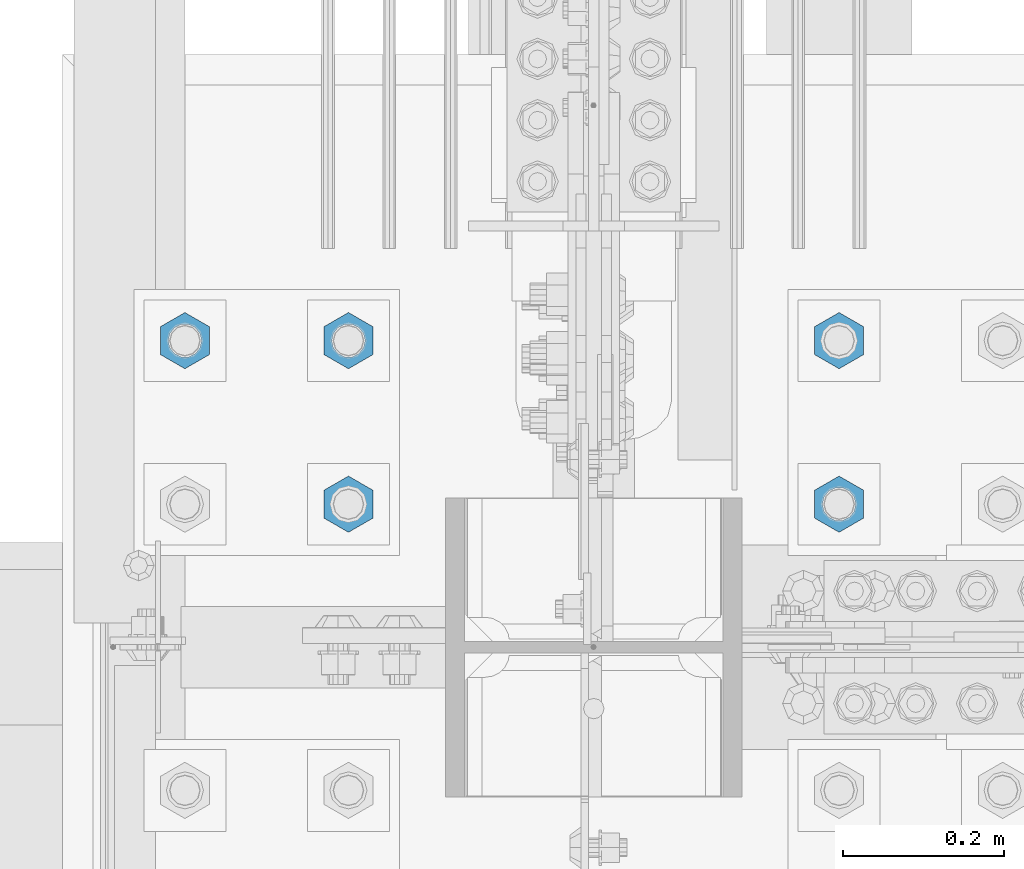
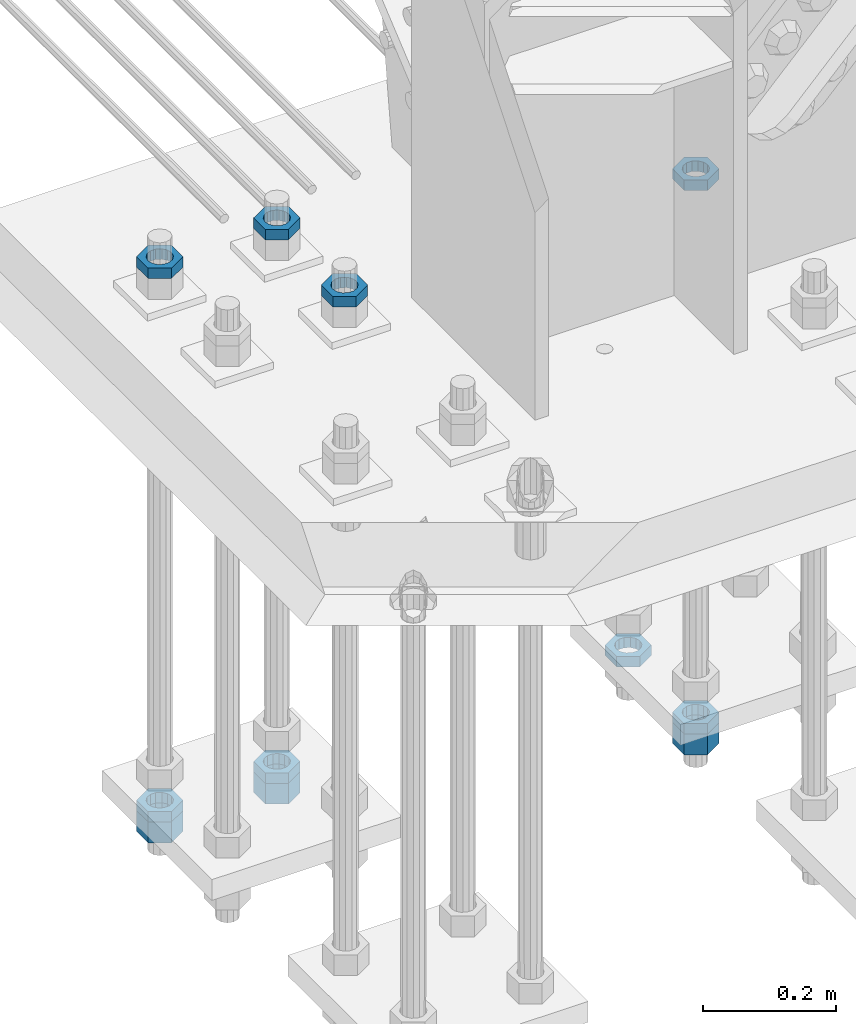
# One storey, part 2805 of 3843: 11 beams, 1 element without a shape of its own.
"""IFC2X3 building model written with IfcOpenShell, lengths in millimetres."""

import ifcopenshell
import ifcopenshell.guid

model = None  # the IFC model being written
_history = None  # IfcOwnerHistory: only IFC2X3 demands one
_inside = {}  # id of a spatial element -> (the spatial element, [elements in it])
_under = {}  # id of a project, library or spatial element -> (it, [spatial elements below it])
_declared = {}  # id of a project -> (the project, [libraries it declares])
_typed = {}  # id of a type object -> (the type object, [elements of that type])
_made_of = {}  # id of a material, layer set ... -> (it, [elements and type objects made of it])


def new_model(schema):
    """Start an empty IFC model of exactly this schema.

    Asked for "IFC4X3", IfcOpenShell would pick the latest addendum, in which some entities
    have other attributes; the version numbers below select the first issue.
    IFC2X3 requires an IfcOwnerHistory on every rooted entity: one is made here for all.
    """
    global model, _history
    if schema == "IFC4X3":
        model = ifcopenshell.file(schema_version=(4, 3, 0, 0))
    else:
        model = ifcopenshell.file(schema=schema)
    _inside.clear()
    _under.clear()
    _declared.clear()
    _typed.clear()
    _made_of.clear()
    _history = None
    if model.schema == "IFC2X3":
        org = make("IfcOrganization", Name="unknown")
        user = make(
            "IfcPersonAndOrganization",
            ThePerson=make("IfcPerson", FamilyName="unknown"),
            TheOrganization=org,
        )
        app = make(
            "IfcApplication",
            ApplicationDeveloper=org,
            Version="unknown",
            ApplicationFullName="unknown",
            ApplicationIdentifier="unknown",
        )
        _history = make(
            "IfcOwnerHistory",
            OwningUser=user,
            OwningApplication=app,
            ChangeAction="ADDED",
            CreationDate=0,
        )
    return model


def make(cls, **values):
    """One entity of the class cls with the attributes given. An attribute that is None is left unset."""
    return model.create_entity(
        cls, **{name: value for name, value in values.items() if value is not None}
    )


def rooted(cls, **values):
    """An entity with a GlobalId (a new one), such as an element, a storey or a relation."""
    return make(cls, GlobalId=ifcopenshell.guid.new(), OwnerHistory=_history, **values)


def si_unit(unit_type, name, prefix=None):
    """IfcSIUnit, for example si_unit("LENGTHUNIT", "METRE", prefix="MILLI")."""
    return make("IfcSIUnit", UnitType=unit_type, Prefix=prefix, Name=name)


def assignment(units):
    """IfcUnitAssignment: the units of a project."""
    return None if units is None else make("IfcUnitAssignment", Units=units)


def point(xyz):
    """IfcCartesianPoint."""
    return None if xyz is None else make("IfcCartesianPoint", Coordinates=xyz)


def direction(xyz):
    """IfcDirection."""
    return None if xyz is None else make("IfcDirection", DirectionRatios=xyz)


def frame(location, z_axis=None, x_axis=None):
    """IfcAxis2Placement3D, a coordinate frame: its origin and axes. An axis left out is left unset."""
    return make(
        "IfcAxis2Placement3D",
        Location=point(location),
        Axis=direction(z_axis),
        RefDirection=direction(x_axis),
    )


def origin_with_axes():
    """The frame at (0, 0, 0) with the z axis (0, 0, 1) and the x axis (1, 0, 0) written out."""
    return frame((0.0, 0.0, 0.0), z_axis=(0.0, 0.0, 1.0), x_axis=(1.0, 0.0, 0.0))


def place(relative_to, where):
    """IfcLocalPlacement: puts the frame where relative to a parent placement (None: the world)."""
    return make(
        "IfcLocalPlacement", PlacementRelTo=relative_to, RelativePlacement=where
    )


def context(
    kind, dimensions, precision=None, world=None, true_north=None, identifier=None
):
    """IfcGeometricRepresentationContext, for example the 3D "Model" context."""
    return make(
        "IfcGeometricRepresentationContext",
        ContextIdentifier=identifier,
        ContextType=kind,
        CoordinateSpaceDimension=dimensions,
        Precision=precision,
        WorldCoordinateSystem=world,
        TrueNorth=true_north,
    )


def subcontext(parent, identifier, kind, view, scale=None):
    """IfcGeometricRepresentationSubContext, for example "Body" below "Model"."""
    return make(
        "IfcGeometricRepresentationSubContext",
        ContextIdentifier=identifier,
        ContextType=kind,
        ParentContext=parent,
        TargetScale=scale,
        TargetView=view,
    )


def project(units=None, contexts=None):
    """IfcProject with its units and contexts."""
    return rooted(
        "IfcProject",
        Name="project",
        RepresentationContexts=contexts,
        UnitsInContext=assignment(units),
    )


def spatial(cls, under=None, at=None, **own):
    """A site, building, storey or space (cls), placed at a placement, below another one or the project."""
    s = rooted(cls, ObjectPlacement=at, **own)
    if under is not None:
        _under.setdefault(under.id(), (under, []))[1].append(s)
    return s


def faces_of(points, faces, orient=None, outer=None):
    """IfcFace entities. A face is a list of loops; a loop is a list of indices into points, from 0.

    orient and outer hold one flag for each loop. By default every Orientation is true, the
    first loop of a face is its IfcFaceOuterBound and the others are IfcFaceBound.
    """
    made = []
    for i, loops in enumerate(faces):
        bounds = []
        for j, loop in enumerate(loops):
            is_outer = j == 0 if outer is None else outer[i][j]
            bounds.append(
                make(
                    "IfcFaceOuterBound" if is_outer else "IfcFaceBound",
                    Bound=make("IfcPolyLoop", Polygon=[points[k] for k in loop]),
                    Orientation=True if orient is None else orient[i][j],
                )
            )
        made.append(make("IfcFace", Bounds=bounds))
    return made


def faceted_brep(points, faces, orient=None, outer=None, voids=None):
    """IfcFacetedBrep: a solid bounded by flat faces; with voids (closed shells), ...WithVoids."""
    shared = [point(p) for p in points]
    hull = make("IfcClosedShell", CfsFaces=faces_of(shared, faces, orient, outer))
    if voids is None:
        return make("IfcFacetedBrep", Outer=hull)
    return make(
        "IfcFacetedBrepWithVoids",
        Outer=hull,
        Voids=[
            make(cls, CfsFaces=faces_of(shared, fs, o, b)) for cls, fs, o, b in voids
        ],
    )


def shape(context_of_items, identifier, shape_type, items):
    """IfcShapeRepresentation: the items that make up one representation, for example the "Body"."""
    return make(
        "IfcShapeRepresentation",
        ContextOfItems=context_of_items,
        RepresentationIdentifier=identifier,
        RepresentationType=shape_type,
        Items=items,
    )


def material(Name=None, Category=None):
    """IfcMaterial."""
    return make("IfcMaterial", Name=Name, Category=Category)


def made_of(thing, what):
    """Note that an element or type object is made of a material, layer set ...; save() writes the relation."""
    if what is not None:
        _made_of.setdefault(what.id(), (what, []))[1].append(thing)
    return thing


def type_object(cls, material=None, **own):
    """A type object (cls), such as IfcWallType, which elements share."""
    return made_of(rooted(cls, **own), material)


def element(
    cls,
    number,
    at=None,
    inside=None,
    cuts=None,
    type_object=None,
    material=None,
    context=None,
    identifier="Body",
    shape_type=None,
    held_by="IfcProductDefinitionShape",
    body=None,
    shapes=None,
    **own,
):
    """One element of the class cls, such as IfcWall. Its Tag is "e" and its number.

    at: its placement. inside: the storey or other place that contains it. cuts: it is an
    opening in that element (IfcRelVoidsElement). A single representation is given by context,
    identifier, shape_type and body (its items); several are given by shapes. held_by: the class
    of the entity that holds the representations. save() writes the other relations.
    """
    e = rooted(cls, Tag="e%d" % number, ObjectPlacement=at, **own)
    if body is not None:
        shapes = [shape(context, identifier, shape_type, body)]
    if shapes is not None:
        e.Representation = make(held_by, Representations=shapes)
    if inside is not None:
        _inside.setdefault(inside.id(), (inside, []))[1].append(e)
    if cuts is not None:
        rooted(
            "IfcRelVoidsElement", RelatingBuildingElement=cuts, RelatedOpeningElement=e
        )
    if type_object is not None:
        _typed.setdefault(type_object.id(), (type_object, []))[1].append(e)
    return made_of(e, material)


def aggregate(whole, parts):
    """IfcRelAggregates: a whole, such as a stair, and the parts it consists of."""
    return rooted("IfcRelAggregates", RelatingObject=whole, RelatedObjects=parts)


def save(model, path):
    """Write the relations noted so far, then the file.

    IfcRelAggregates (storeys below a building ...), IfcRelContainedInSpatialStructure (elements
    in a storey), IfcRelDefinesByType, IfcRelAssociatesMaterial and IfcRelDeclares: one each for
    every whole, place, type object, material and project.
    """
    for whole, parts in _under.values():
        aggregate(whole, parts)
    for where, things in _inside.values():
        rooted(
            "IfcRelContainedInSpatialStructure",
            RelatedElements=things,
            RelatingStructure=where,
        )
    for kind, things in _typed.values():
        rooted("IfcRelDefinesByType", RelatedObjects=things, RelatingType=kind)
    for what, things in _made_of.values():
        rooted("IfcRelAssociatesMaterial", RelatedObjects=things, RelatingMaterial=what)
    for by, libraries in _declared.values():
        rooted("IfcRelDeclares", RelatingContext=by, RelatedDefinitions=libraries)
    model.write(path)


model = new_model("IFC2X3")

# Units and contexts
model_context = context("Model", 3, precision=1e-05, world=origin_with_axes())
body_context = subcontext(model_context, "Body", "Model", "MODEL_VIEW")
ifc_project = project(units=[si_unit("LENGTHUNIT", "METRE", prefix="MILLI"), si_unit("AREAUNIT", "SQUARE_METRE"), si_unit("VOLUMEUNIT", "CUBIC_METRE"), si_unit("MASSUNIT", "GRAM", prefix="KILO"), si_unit("TIMEUNIT", "SECOND"), si_unit("PLANEANGLEUNIT", "RADIAN"), si_unit("SOLIDANGLEUNIT", "STERADIAN"), si_unit("THERMODYNAMICTEMPERATUREUNIT", "DEGREE_CELSIUS"), si_unit("LUMINOUSINTENSITYUNIT", "LUMEN")], contexts=[model_context])

# Site, building, storey
site_placement = place(None, origin_with_axes())
site = spatial("IfcSite", under=ifc_project, at=site_placement, CompositionType="ELEMENT")
building_placement = place(site_placement, origin_with_axes())
building = spatial("IfcBuilding", under=site, at=building_placement, Name="Undefined", CompositionType="ELEMENT")
storey_placement = place(building_placement, origin_with_axes())
storey = spatial("IfcBuildingStorey", under=building, at=storey_placement, Name="Undefined", CompositionType="ELEMENT", Elevation=0.0)

# Assembly, beams
assembly_placement = place(storey_placement, origin_with_axes())
assembly = element("IfcElementAssembly", 1, at=assembly_placement, inside=storey, Name="TEMPLATE", AssemblyPlace="NOTDEFINED", PredefinedType="RIGID_FRAME")
ifc_material = material(Name="STEEL/A572-50")
beam_type_1 = type_object("IfcBeamType", Name="1-1/2_HEAVY_HEX_NUT", PredefinedType="NOTDEFINED")
beam_1_placement = place(assembly_placement, frame((76504.799987793, 15379.6999969482, 29203.6500015259), z_axis=(1.0, 0.0, 0.0), x_axis=(0.0, 0.0, -1.0)))
beam_1 = element("IfcBeam", 2, at=beam_1_placement, type_object=beam_type_1, material=ifc_material, Name="NUT", ObjectType="1-1/2_HEAVY_HEX_NUT", context=body_context, shape_type="Brep", body=[
    faceted_brep([(0.0, -34.9199981689453, 0.0), (0.0, -17.4599990844727, -30.25), (38.0999999999985, -17.4599990844727, -30.25), (38.0999999999985, -34.9199981689453, 0.0), (0.0, 17.4599990844727, -30.25), (38.0999999999985, 17.4599990844727, -30.25), (0.0, 34.9199981689453, 0.0), (38.0999999999985, 34.9199981689453, 0.0), (0.0, 17.4599990844727, 30.25), (38.0999999999985, 17.4599990844727, 30.25), (0.0, -17.4599990844727, 30.25), (38.0999999999985, -17.4599990844727, 30.25), (0.0, 0.0, 20.6399993896484), (0.0, 8.9553601105581, 18.5959968835959), (38.0999999999985, 8.9553601105581, 18.5959968835959), (38.0999999999985, 0.0, 20.6399993896484), (0.0, 16.1370013209525, 12.8688291298167), (38.0999999999985, 16.1370013209525, 12.8688291298167), (0.0, 20.1225115123816, 4.59283194104501), (38.0999999999985, 20.1225115123816, 4.59283194104501), (0.0, 20.1225115123816, -4.59283194104501), (38.0999999999985, 20.1225115123816, -4.59283194104501), (0.0, 16.1370013209525, -12.8688291298167), (38.0999999999985, 16.1370013209525, -12.8688291298167), (0.0, 8.9553601105581, -18.5959968835959), (38.0999999999985, 8.9553601105581, -18.5959968835959), (0.0, 0.0, -20.6399993896484), (38.0999999999985, 0.0, -20.6399993896484), (0.0, -8.9553601105581, -18.5959968835959), (38.0999999999985, -8.9553601105581, -18.5959968835959), (0.0, -16.1370013209525, -12.8688291298167), (38.0999999999985, -16.1370013209525, -12.8688291298167), (0.0, -20.1225115123816, -4.59283194104501), (38.0999999999985, -20.1225115123816, -4.59283194104501), (0.0, -20.1225115123816, 4.59283194104501), (38.0999999999985, -20.1225115123816, 4.59283194104501), (0.0, -16.1370013209525, 12.8688291298167), (38.0999999999985, -16.1370013209525, 12.8688291298167), (0.0, -8.9553601105581, 18.5959968835959), (38.0999999999985, -8.9553601105581, 18.5959968835959)], [[[0, 1, 2, 3]], [[1, 4, 5, 2]], [[4, 6, 7, 5]], [[6, 8, 9, 7]], [[8, 10, 11, 9]], [[10, 0, 3, 11]], [[12, 13, 14, 15]], [[13, 16, 17, 14]], [[16, 18, 19, 17]], [[18, 20, 21, 19]], [[20, 22, 23, 21]], [[22, 24, 25, 23]], [[24, 26, 27, 25]], [[26, 28, 29, 27]], [[28, 30, 31, 29]], [[30, 32, 33, 31]], [[32, 34, 35, 33]], [[34, 36, 37, 35]], [[36, 38, 39, 37]], [[38, 12, 15, 39]], [[5, 7, 9, 11, 3, 2], [17, 19, 21, 23, 25, 27, 29, 31, 33, 35, 37, 39, 15, 14]], [[10, 8, 6, 4, 1, 0], [38, 36, 34, 32, 30, 28, 26, 24, 22, 20, 18, 16, 13, 12]]]),
])
beam_2_placement = place(assembly_placement, frame((76708.0, 15379.6999969482, 29203.6500015259), z_axis=(1.0, 0.0, 0.0), x_axis=(0.0, 0.0, -1.0)))
beam_2 = element("IfcBeam", 3, at=beam_2_placement, type_object=beam_type_1, material=ifc_material, Name="NUT", ObjectType="1-1/2_HEAVY_HEX_NUT", context=body_context, shape_type="Brep", body=[
    faceted_brep([(0.0, -34.9199981689453, 0.0), (0.0, -17.4599990844727, -30.25), (38.0999999999985, -17.4599990844727, -30.25), (38.0999999999985, -34.9199981689453, 0.0), (0.0, 17.4599990844727, -30.25), (38.0999999999985, 17.4599990844727, -30.25), (0.0, 34.9199981689453, 0.0), (38.0999999999985, 34.9199981689453, 0.0), (0.0, 17.4599990844727, 30.25), (38.0999999999985, 17.4599990844727, 30.25), (0.0, -17.4599990844727, 30.25), (38.0999999999985, -17.4599990844727, 30.25), (0.0, 0.0, 20.6399993896484), (0.0, 8.9553601105581, 18.5959968835959), (38.0999999999985, 8.9553601105581, 18.5959968835959), (38.0999999999985, 0.0, 20.6399993896484), (0.0, 16.1370013209525, 12.8688291298167), (38.0999999999985, 16.1370013209525, 12.8688291298167), (0.0, 20.1225115123816, 4.59283194104501), (38.0999999999985, 20.1225115123816, 4.59283194104501), (0.0, 20.1225115123816, -4.59283194104501), (38.0999999999985, 20.1225115123816, -4.59283194104501), (0.0, 16.1370013209525, -12.8688291298167), (38.0999999999985, 16.1370013209525, -12.8688291298167), (0.0, 8.9553601105581, -18.5959968835959), (38.0999999999985, 8.9553601105581, -18.5959968835959), (0.0, 0.0, -20.6399993896484), (38.0999999999985, 0.0, -20.6399993896484), (0.0, -8.9553601105581, -18.5959968835959), (38.0999999999985, -8.9553601105581, -18.5959968835959), (0.0, -16.1370013209525, -12.8688291298167), (38.0999999999985, -16.1370013209525, -12.8688291298167), (0.0, -20.1225115123816, -4.59283194104501), (38.0999999999985, -20.1225115123816, -4.59283194104501), (0.0, -20.1225115123816, 4.59283194104501), (38.0999999999985, -20.1225115123816, 4.59283194104501), (0.0, -16.1370013209525, 12.8688291298167), (38.0999999999985, -16.1370013209525, 12.8688291298167), (0.0, -8.9553601105581, 18.5959968835959), (38.0999999999985, -8.9553601105581, 18.5959968835959)], [[[0, 1, 2, 3]], [[1, 4, 5, 2]], [[4, 6, 7, 5]], [[6, 8, 9, 7]], [[8, 10, 11, 9]], [[10, 0, 3, 11]], [[12, 13, 14, 15]], [[13, 16, 17, 14]], [[16, 18, 19, 17]], [[18, 20, 21, 19]], [[20, 22, 23, 21]], [[22, 24, 25, 23]], [[24, 26, 27, 25]], [[26, 28, 29, 27]], [[28, 30, 31, 29]], [[30, 32, 33, 31]], [[32, 34, 35, 33]], [[34, 36, 37, 35]], [[36, 38, 39, 37]], [[38, 12, 15, 39]], [[5, 7, 9, 11, 3, 2], [17, 19, 21, 23, 25, 27, 29, 31, 33, 35, 37, 39, 15, 14]], [[10, 8, 6, 4, 1, 0], [38, 36, 34, 32, 30, 28, 26, 24, 22, 20, 18, 16, 13, 12]]]),
])
beam_3_placement = place(assembly_placement, frame((77317.599987793, 15176.5, 29203.6500015259), z_axis=(1.0, 0.0, 0.0), x_axis=(0.0, 0.0, -1.0)))
beam_3 = element("IfcBeam", 4, at=beam_3_placement, type_object=beam_type_1, material=ifc_material, Name="NUT", ObjectType="1-1/2_HEAVY_HEX_NUT", context=body_context, shape_type="Brep", body=[
    faceted_brep([(0.0, -34.9199981689453, 0.0), (0.0, -17.4599990844727, -30.25), (38.0999999999985, -17.4599990844727, -30.25), (38.0999999999985, -34.9199981689453, 0.0), (0.0, 17.4599990844727, -30.25), (38.0999999999985, 17.4599990844727, -30.25), (0.0, 34.9199981689453, 0.0), (38.0999999999985, 34.9199981689453, 0.0), (0.0, 17.4599990844727, 30.25), (38.0999999999985, 17.4599990844727, 30.25), (0.0, -17.4599990844727, 30.25), (38.0999999999985, -17.4599990844727, 30.25), (0.0, 0.0, 20.6399993896484), (0.0, 8.9553601105581, 18.5959968835959), (38.0999999999985, 8.9553601105581, 18.5959968835959), (38.0999999999985, 0.0, 20.6399993896484), (0.0, 16.1370013209525, 12.8688291298167), (38.0999999999985, 16.1370013209525, 12.8688291298167), (0.0, 20.1225115123816, 4.59283194104501), (38.0999999999985, 20.1225115123816, 4.59283194104501), (0.0, 20.1225115123816, -4.59283194104501), (38.0999999999985, 20.1225115123816, -4.59283194104501), (0.0, 16.1370013209525, -12.8688291298167), (38.0999999999985, 16.1370013209525, -12.8688291298167), (0.0, 8.9553601105581, -18.5959968835959), (38.0999999999985, 8.9553601105581, -18.5959968835959), (0.0, 0.0, -20.6399993896484), (38.0999999999985, 0.0, -20.6399993896484), (0.0, -8.9553601105581, -18.5959968835959), (38.0999999999985, -8.9553601105581, -18.5959968835959), (0.0, -16.1370013209525, -12.8688291298167), (38.0999999999985, -16.1370013209525, -12.8688291298167), (0.0, -20.1225115123816, -4.59283194104501), (38.0999999999985, -20.1225115123816, -4.59283194104501), (0.0, -20.1225115123816, 4.59283194104501), (38.0999999999985, -20.1225115123816, 4.59283194104501), (0.0, -16.1370013209525, 12.8688291298167), (38.0999999999985, -16.1370013209525, 12.8688291298167), (0.0, -8.9553601105581, 18.5959968835959), (38.0999999999985, -8.9553601105581, 18.5959968835959)], [[[0, 1, 2, 3]], [[1, 4, 5, 2]], [[4, 6, 7, 5]], [[6, 8, 9, 7]], [[8, 10, 11, 9]], [[10, 0, 3, 11]], [[12, 13, 14, 15]], [[13, 16, 17, 14]], [[16, 18, 19, 17]], [[18, 20, 21, 19]], [[20, 22, 23, 21]], [[22, 24, 25, 23]], [[24, 26, 27, 25]], [[26, 28, 29, 27]], [[28, 30, 31, 29]], [[30, 32, 33, 31]], [[32, 34, 35, 33]], [[34, 36, 37, 35]], [[36, 38, 39, 37]], [[38, 12, 15, 39]], [[5, 7, 9, 11, 3, 2], [17, 19, 21, 23, 25, 27, 29, 31, 33, 35, 37, 39, 15, 14]], [[10, 8, 6, 4, 1, 0], [38, 36, 34, 32, 30, 28, 26, 24, 22, 20, 18, 16, 13, 12]]]),
])
beam_type_2 = type_object("IfcBeamType", Name="1-1/2_HALF_NUT", PredefinedType="NOTDEFINED")
beam_4_placement = place(assembly_placement, frame((76708.0, 15176.5, 30219.65), z_axis=(1.0, 0.0, 0.0), x_axis=(0.0, 0.0, -1.0)))
beam_4 = element("IfcBeam", 5, at=beam_4_placement, type_object=beam_type_2, material=ifc_material, Name="NUT", ObjectType="1-1/2_HALF_NUT", context=body_context, shape_type="Brep", body=[
    faceted_brep([(0.0, -34.9199981689453, 0.0), (0.0, -17.4599990844727, -30.25), (19.0500000000029, -17.4599990844727, -30.25), (19.0500000000029, -34.9199981689453, 0.0), (0.0, 17.4599990844727, -30.25), (19.0500000000029, 17.4599990844727, -30.25), (0.0, 34.9199981689453, 0.0), (19.0500000000029, 34.9199981689453, 0.0), (0.0, 17.4599990844727, 30.25), (19.0500000000029, 17.4599990844727, 30.25), (0.0, -17.4599990844727, 30.25), (19.0500000000029, -17.4599990844727, 30.25), (0.0, 0.0, 20.6399993896484), (0.0, 8.9553601105581, 18.5959968835959), (19.0500000000029, 8.95536011056538, 18.5959968835959), (19.0500000000029, 0.0, 20.6399993896484), (0.0, 16.1370013209525, 12.8688291298167), (19.0500000000029, 16.1370013209489, 12.8688291298167), (0.0, 20.1225115123816, 4.59283194104501), (19.0500000000029, 20.1225115123852, 4.59283194104501), (0.0, 20.1225115123816, -4.59283194104501), (19.0500000000029, 20.1225115123852, -4.59283194104501), (0.0, 16.1370013209525, -12.8688291298167), (19.0500000000029, 16.1370013209489, -12.8688291298167), (0.0, 8.9553601105581, -18.5959968835959), (19.0500000000029, 8.95536011056538, -18.5959968835959), (0.0, 0.0, -20.6399993896484), (19.0500000000029, 0.0, -20.6399993896484), (0.0, -8.9553601105581, -18.5959968835959), (19.0500000000029, -8.95536011056538, -18.5959968835959), (0.0, -16.1370013209525, -12.8688291298167), (19.0500000000029, -16.1370013209489, -12.8688291298167), (0.0, -20.1225115123816, -4.59283194104501), (19.0500000000029, -20.1225115123852, -4.59283194104501), (0.0, -20.1225115123816, 4.59283194104501), (19.0500000000029, -20.1225115123852, 4.59283194104501), (0.0, -16.1370013209525, 12.8688291298167), (19.0500000000029, -16.1370013209489, 12.8688291298167), (0.0, -8.9553601105581, 18.5959968835959), (19.0500000000029, -8.95536011056538, 18.5959968835959)], [[[0, 1, 2, 3]], [[1, 4, 5, 2]], [[4, 6, 7, 5]], [[6, 8, 9, 7]], [[8, 10, 11, 9]], [[10, 0, 3, 11]], [[12, 13, 14, 15]], [[13, 16, 17, 14]], [[16, 18, 19, 17]], [[18, 20, 21, 19]], [[20, 22, 23, 21]], [[22, 24, 25, 23]], [[24, 26, 27, 25]], [[26, 28, 29, 27]], [[28, 30, 31, 29]], [[30, 32, 33, 31]], [[32, 34, 35, 33]], [[34, 36, 37, 35]], [[36, 38, 39, 37]], [[38, 12, 15, 39]], [[5, 7, 9, 11, 3, 2], [17, 19, 21, 23, 25, 27, 29, 31, 33, 35, 37, 39, 15, 14]], [[10, 8, 6, 4, 1, 0], [38, 36, 34, 32, 30, 28, 26, 24, 22, 20, 18, 16, 13, 12]]]),
])
beam_5_placement = place(assembly_placement, frame((76504.799987793, 15379.6999969482, 29222.7), z_axis=(1.0, 0.0, 0.0), x_axis=(0.0, 0.0, -1.0)))
beam_5 = element("IfcBeam", 6, at=beam_5_placement, type_object=beam_type_2, material=ifc_material, Name="NUT", ObjectType="1-1/2_HALF_NUT", context=body_context, shape_type="Brep", body=[
    faceted_brep([(0.0, -34.9199981689453, 0.0), (0.0, -17.4599990844727, -30.25), (19.0500000000029, -17.4599990844727, -30.25), (19.0500000000029, -34.9199981689453, 0.0), (0.0, 17.4599990844727, -30.25), (19.0500000000029, 17.4599990844727, -30.25), (0.0, 34.9199981689453, 0.0), (19.0500000000029, 34.9199981689453, 0.0), (0.0, 17.4599990844727, 30.25), (19.0500000000029, 17.4599990844727, 30.25), (0.0, -17.4599990844727, 30.25), (19.0500000000029, -17.4599990844727, 30.25), (0.0, 0.0, 20.6399993896484), (0.0, 8.9553601105581, 18.5959968835959), (19.0500000000029, 8.95536011056538, 18.5959968835959), (19.0500000000029, 0.0, 20.6399993896484), (0.0, 16.1370013209525, 12.8688291298167), (19.0500000000029, 16.1370013209489, 12.8688291298167), (0.0, 20.1225115123816, 4.59283194104501), (19.0500000000029, 20.1225115123852, 4.59283194104501), (0.0, 20.1225115123816, -4.59283194104501), (19.0500000000029, 20.1225115123852, -4.59283194104501), (0.0, 16.1370013209525, -12.8688291298167), (19.0500000000029, 16.1370013209489, -12.8688291298167), (0.0, 8.9553601105581, -18.5959968835959), (19.0500000000029, 8.95536011056538, -18.5959968835959), (0.0, 0.0, -20.6399993896484), (19.0500000000029, 0.0, -20.6399993896484), (0.0, -8.9553601105581, -18.5959968835959), (19.0500000000029, -8.95536011056538, -18.5959968835959), (0.0, -16.1370013209525, -12.8688291298167), (19.0500000000029, -16.1370013209489, -12.8688291298167), (0.0, -20.1225115123816, -4.59283194104501), (19.0500000000029, -20.1225115123852, -4.59283194104501), (0.0, -20.1225115123816, 4.59283194104501), (19.0500000000029, -20.1225115123852, 4.59283194104501), (0.0, -16.1370013209525, 12.8688291298167), (19.0500000000029, -16.1370013209489, 12.8688291298167), (0.0, -8.9553601105581, 18.5959968835959), (19.0500000000029, -8.95536011056538, 18.5959968835959)], [[[0, 1, 2, 3]], [[1, 4, 5, 2]], [[4, 6, 7, 5]], [[6, 8, 9, 7]], [[8, 10, 11, 9]], [[10, 0, 3, 11]], [[12, 13, 14, 15]], [[13, 16, 17, 14]], [[16, 18, 19, 17]], [[18, 20, 21, 19]], [[20, 22, 23, 21]], [[22, 24, 25, 23]], [[24, 26, 27, 25]], [[26, 28, 29, 27]], [[28, 30, 31, 29]], [[30, 32, 33, 31]], [[32, 34, 35, 33]], [[34, 36, 37, 35]], [[36, 38, 39, 37]], [[38, 12, 15, 39]], [[5, 7, 9, 11, 3, 2], [17, 19, 21, 23, 25, 27, 29, 31, 33, 35, 37, 39, 15, 14]], [[10, 8, 6, 4, 1, 0], [38, 36, 34, 32, 30, 28, 26, 24, 22, 20, 18, 16, 13, 12]]]),
])
beam_6_placement = place(assembly_placement, frame((76504.799987793, 15379.6999969482, 30219.65), z_axis=(1.0, 0.0, 0.0), x_axis=(0.0, 0.0, -1.0)))
beam_6 = element("IfcBeam", 7, at=beam_6_placement, type_object=beam_type_2, material=ifc_material, Name="NUT", ObjectType="1-1/2_HALF_NUT", context=body_context, shape_type="Brep", body=[
    faceted_brep([(0.0, -34.9199981689453, 0.0), (0.0, -17.4599990844727, -30.25), (19.0500000000029, -17.4599990844727, -30.25), (19.0500000000029, -34.9199981689453, 0.0), (0.0, 17.4599990844727, -30.25), (19.0500000000029, 17.4599990844727, -30.25), (0.0, 34.9199981689453, 0.0), (19.0500000000029, 34.9199981689453, 0.0), (0.0, 17.4599990844727, 30.25), (19.0500000000029, 17.4599990844727, 30.25), (0.0, -17.4599990844727, 30.25), (19.0500000000029, -17.4599990844727, 30.25), (0.0, 0.0, 20.6399993896484), (0.0, 8.9553601105581, 18.5959968835959), (19.0500000000029, 8.95536011056538, 18.5959968835959), (19.0500000000029, 0.0, 20.6399993896484), (0.0, 16.1370013209525, 12.8688291298167), (19.0500000000029, 16.1370013209489, 12.8688291298167), (0.0, 20.1225115123816, 4.59283194104501), (19.0500000000029, 20.1225115123852, 4.59283194104501), (0.0, 20.1225115123816, -4.59283194104501), (19.0500000000029, 20.1225115123852, -4.59283194104501), (0.0, 16.1370013209525, -12.8688291298167), (19.0500000000029, 16.1370013209489, -12.8688291298167), (0.0, 8.9553601105581, -18.5959968835959), (19.0500000000029, 8.95536011056538, -18.5959968835959), (0.0, 0.0, -20.6399993896484), (19.0500000000029, 0.0, -20.6399993896484), (0.0, -8.9553601105581, -18.5959968835959), (19.0500000000029, -8.95536011056538, -18.5959968835959), (0.0, -16.1370013209525, -12.8688291298167), (19.0500000000029, -16.1370013209489, -12.8688291298167), (0.0, -20.1225115123816, -4.59283194104501), (19.0500000000029, -20.1225115123852, -4.59283194104501), (0.0, -20.1225115123816, 4.59283194104501), (19.0500000000029, -20.1225115123852, 4.59283194104501), (0.0, -16.1370013209525, 12.8688291298167), (19.0500000000029, -16.1370013209489, 12.8688291298167), (0.0, -8.9553601105581, 18.5959968835959), (19.0500000000029, -8.95536011056538, 18.5959968835959)], [[[0, 1, 2, 3]], [[1, 4, 5, 2]], [[4, 6, 7, 5]], [[6, 8, 9, 7]], [[8, 10, 11, 9]], [[10, 0, 3, 11]], [[12, 13, 14, 15]], [[13, 16, 17, 14]], [[16, 18, 19, 17]], [[18, 20, 21, 19]], [[20, 22, 23, 21]], [[22, 24, 25, 23]], [[24, 26, 27, 25]], [[26, 28, 29, 27]], [[28, 30, 31, 29]], [[30, 32, 33, 31]], [[32, 34, 35, 33]], [[34, 36, 37, 35]], [[36, 38, 39, 37]], [[38, 12, 15, 39]], [[5, 7, 9, 11, 3, 2], [17, 19, 21, 23, 25, 27, 29, 31, 33, 35, 37, 39, 15, 14]], [[10, 8, 6, 4, 1, 0], [38, 36, 34, 32, 30, 28, 26, 24, 22, 20, 18, 16, 13, 12]]]),
])
beam_7_placement = place(assembly_placement, frame((76708.0, 15379.6999969482, 29222.7), z_axis=(1.0, 0.0, 0.0), x_axis=(0.0, 0.0, -1.0)))
beam_7 = element("IfcBeam", 8, at=beam_7_placement, type_object=beam_type_2, material=ifc_material, Name="NUT", ObjectType="1-1/2_HALF_NUT", context=body_context, shape_type="Brep", body=[
    faceted_brep([(0.0, -34.9199981689453, 0.0), (0.0, -17.4599990844727, -30.25), (19.0500000000029, -17.4599990844727, -30.25), (19.0500000000029, -34.9199981689453, 0.0), (0.0, 17.4599990844727, -30.25), (19.0500000000029, 17.4599990844727, -30.25), (0.0, 34.9199981689453, 0.0), (19.0500000000029, 34.9199981689453, 0.0), (0.0, 17.4599990844727, 30.25), (19.0500000000029, 17.4599990844727, 30.25), (0.0, -17.4599990844727, 30.25), (19.0500000000029, -17.4599990844727, 30.25), (0.0, 0.0, 20.6399993896484), (0.0, 8.9553601105581, 18.5959968835959), (19.0500000000029, 8.95536011056538, 18.5959968835959), (19.0500000000029, 0.0, 20.6399993896484), (0.0, 16.1370013209525, 12.8688291298167), (19.0500000000029, 16.1370013209489, 12.8688291298167), (0.0, 20.1225115123816, 4.59283194104501), (19.0500000000029, 20.1225115123852, 4.59283194104501), (0.0, 20.1225115123816, -4.59283194104501), (19.0500000000029, 20.1225115123852, -4.59283194104501), (0.0, 16.1370013209525, -12.8688291298167), (19.0500000000029, 16.1370013209489, -12.8688291298167), (0.0, 8.9553601105581, -18.5959968835959), (19.0500000000029, 8.95536011056538, -18.5959968835959), (0.0, 0.0, -20.6399993896484), (19.0500000000029, 0.0, -20.6399993896484), (0.0, -8.9553601105581, -18.5959968835959), (19.0500000000029, -8.95536011056538, -18.5959968835959), (0.0, -16.1370013209525, -12.8688291298167), (19.0500000000029, -16.1370013209489, -12.8688291298167), (0.0, -20.1225115123816, -4.59283194104501), (19.0500000000029, -20.1225115123852, -4.59283194104501), (0.0, -20.1225115123816, 4.59283194104501), (19.0500000000029, -20.1225115123852, 4.59283194104501), (0.0, -16.1370013209525, 12.8688291298167), (19.0500000000029, -16.1370013209489, 12.8688291298167), (0.0, -8.9553601105581, 18.5959968835959), (19.0500000000029, -8.95536011056538, 18.5959968835959)], [[[0, 1, 2, 3]], [[1, 4, 5, 2]], [[4, 6, 7, 5]], [[6, 8, 9, 7]], [[8, 10, 11, 9]], [[10, 0, 3, 11]], [[12, 13, 14, 15]], [[13, 16, 17, 14]], [[16, 18, 19, 17]], [[18, 20, 21, 19]], [[20, 22, 23, 21]], [[22, 24, 25, 23]], [[24, 26, 27, 25]], [[26, 28, 29, 27]], [[28, 30, 31, 29]], [[30, 32, 33, 31]], [[32, 34, 35, 33]], [[34, 36, 37, 35]], [[36, 38, 39, 37]], [[38, 12, 15, 39]], [[5, 7, 9, 11, 3, 2], [17, 19, 21, 23, 25, 27, 29, 31, 33, 35, 37, 39, 15, 14]], [[10, 8, 6, 4, 1, 0], [38, 36, 34, 32, 30, 28, 26, 24, 22, 20, 18, 16, 13, 12]]]),
])
beam_8_placement = place(assembly_placement, frame((76708.0, 15379.6999969482, 30219.65), z_axis=(1.0, 0.0, 0.0), x_axis=(0.0, 0.0, -1.0)))
beam_8 = element("IfcBeam", 9, at=beam_8_placement, type_object=beam_type_2, material=ifc_material, Name="NUT", ObjectType="1-1/2_HALF_NUT", context=body_context, shape_type="Brep", body=[
    faceted_brep([(0.0, -34.9199981689453, 0.0), (0.0, -17.4599990844727, -30.25), (19.0500000000029, -17.4599990844727, -30.25), (19.0500000000029, -34.9199981689453, 0.0), (0.0, 17.4599990844727, -30.25), (19.0500000000029, 17.4599990844727, -30.25), (0.0, 34.9199981689453, 0.0), (19.0500000000029, 34.9199981689453, 0.0), (0.0, 17.4599990844727, 30.25), (19.0500000000029, 17.4599990844727, 30.25), (0.0, -17.4599990844727, 30.25), (19.0500000000029, -17.4599990844727, 30.25), (0.0, 0.0, 20.6399993896484), (0.0, 8.9553601105581, 18.5959968835959), (19.0500000000029, 8.95536011056538, 18.5959968835959), (19.0500000000029, 0.0, 20.6399993896484), (0.0, 16.1370013209525, 12.8688291298167), (19.0500000000029, 16.1370013209489, 12.8688291298167), (0.0, 20.1225115123816, 4.59283194104501), (19.0500000000029, 20.1225115123852, 4.59283194104501), (0.0, 20.1225115123816, -4.59283194104501), (19.0500000000029, 20.1225115123852, -4.59283194104501), (0.0, 16.1370013209525, -12.8688291298167), (19.0500000000029, 16.1370013209489, -12.8688291298167), (0.0, 8.9553601105581, -18.5959968835959), (19.0500000000029, 8.95536011056538, -18.5959968835959), (0.0, 0.0, -20.6399993896484), (19.0500000000029, 0.0, -20.6399993896484), (0.0, -8.9553601105581, -18.5959968835959), (19.0500000000029, -8.95536011056538, -18.5959968835959), (0.0, -16.1370013209525, -12.8688291298167), (19.0500000000029, -16.1370013209489, -12.8688291298167), (0.0, -20.1225115123816, -4.59283194104501), (19.0500000000029, -20.1225115123852, -4.59283194104501), (0.0, -20.1225115123816, 4.59283194104501), (19.0500000000029, -20.1225115123852, 4.59283194104501), (0.0, -16.1370013209525, 12.8688291298167), (19.0500000000029, -16.1370013209489, 12.8688291298167), (0.0, -8.9553601105581, 18.5959968835959), (19.0500000000029, -8.95536011056538, 18.5959968835959)], [[[0, 1, 2, 3]], [[1, 4, 5, 2]], [[4, 6, 7, 5]], [[6, 8, 9, 7]], [[8, 10, 11, 9]], [[10, 0, 3, 11]], [[12, 13, 14, 15]], [[13, 16, 17, 14]], [[16, 18, 19, 17]], [[18, 20, 21, 19]], [[20, 22, 23, 21]], [[22, 24, 25, 23]], [[24, 26, 27, 25]], [[26, 28, 29, 27]], [[28, 30, 31, 29]], [[30, 32, 33, 31]], [[32, 34, 35, 33]], [[34, 36, 37, 35]], [[36, 38, 39, 37]], [[38, 12, 15, 39]], [[5, 7, 9, 11, 3, 2], [17, 19, 21, 23, 25, 27, 29, 31, 33, 35, 37, 39, 15, 14]], [[10, 8, 6, 4, 1, 0], [38, 36, 34, 32, 30, 28, 26, 24, 22, 20, 18, 16, 13, 12]]]),
])
beam_9_placement = place(assembly_placement, frame((77317.599987793, 15176.5, 29222.7), z_axis=(1.0, 0.0, 0.0), x_axis=(0.0, 0.0, -1.0)))
beam_9 = element("IfcBeam", 10, at=beam_9_placement, type_object=beam_type_2, material=ifc_material, Name="NUT", ObjectType="1-1/2_HALF_NUT", context=body_context, shape_type="Brep", body=[
    faceted_brep([(0.0, -34.9199981689453, 0.0), (0.0, -17.4599990844727, -30.25), (19.0500000000029, -17.4599990844727, -30.25), (19.0500000000029, -34.9199981689453, 0.0), (0.0, 17.4599990844727, -30.25), (19.0500000000029, 17.4599990844727, -30.25), (0.0, 34.9199981689453, 0.0), (19.0500000000029, 34.9199981689453, 0.0), (0.0, 17.4599990844727, 30.25), (19.0500000000029, 17.4599990844727, 30.25), (0.0, -17.4599990844727, 30.25), (19.0500000000029, -17.4599990844727, 30.25), (0.0, 0.0, 20.6399993896484), (0.0, 8.9553601105581, 18.5959968835959), (19.0500000000029, 8.95536011056538, 18.5959968835959), (19.0500000000029, 0.0, 20.6399993896484), (0.0, 16.1370013209525, 12.8688291298167), (19.0500000000029, 16.1370013209489, 12.8688291298167), (0.0, 20.1225115123816, 4.59283194104501), (19.0500000000029, 20.1225115123852, 4.59283194104501), (0.0, 20.1225115123816, -4.59283194104501), (19.0500000000029, 20.1225115123852, -4.59283194104501), (0.0, 16.1370013209525, -12.8688291298167), (19.0500000000029, 16.1370013209489, -12.8688291298167), (0.0, 8.9553601105581, -18.5959968835959), (19.0500000000029, 8.95536011056538, -18.5959968835959), (0.0, 0.0, -20.6399993896484), (19.0500000000029, 0.0, -20.6399993896484), (0.0, -8.9553601105581, -18.5959968835959), (19.0500000000029, -8.95536011056538, -18.5959968835959), (0.0, -16.1370013209525, -12.8688291298167), (19.0500000000029, -16.1370013209489, -12.8688291298167), (0.0, -20.1225115123816, -4.59283194104501), (19.0500000000029, -20.1225115123852, -4.59283194104501), (0.0, -20.1225115123816, 4.59283194104501), (19.0500000000029, -20.1225115123852, 4.59283194104501), (0.0, -16.1370013209525, 12.8688291298167), (19.0500000000029, -16.1370013209489, 12.8688291298167), (0.0, -8.9553601105581, 18.5959968835959), (19.0500000000029, -8.95536011056538, 18.5959968835959)], [[[0, 1, 2, 3]], [[1, 4, 5, 2]], [[4, 6, 7, 5]], [[6, 8, 9, 7]], [[8, 10, 11, 9]], [[10, 0, 3, 11]], [[12, 13, 14, 15]], [[13, 16, 17, 14]], [[16, 18, 19, 17]], [[18, 20, 21, 19]], [[20, 22, 23, 21]], [[22, 24, 25, 23]], [[24, 26, 27, 25]], [[26, 28, 29, 27]], [[28, 30, 31, 29]], [[30, 32, 33, 31]], [[32, 34, 35, 33]], [[34, 36, 37, 35]], [[36, 38, 39, 37]], [[38, 12, 15, 39]], [[5, 7, 9, 11, 3, 2], [17, 19, 21, 23, 25, 27, 29, 31, 33, 35, 37, 39, 15, 14]], [[10, 8, 6, 4, 1, 0], [38, 36, 34, 32, 30, 28, 26, 24, 22, 20, 18, 16, 13, 12]]]),
])
beam_10_placement = place(assembly_placement, frame((77317.599987793, 15176.5, 30219.65), z_axis=(1.0, 0.0, 0.0), x_axis=(0.0, 0.0, -1.0)))
beam_10 = element("IfcBeam", 11, at=beam_10_placement, type_object=beam_type_2, material=ifc_material, Name="NUT", ObjectType="1-1/2_HALF_NUT", context=body_context, shape_type="Brep", body=[
    faceted_brep([(0.0, -34.9199981689453, 0.0), (0.0, -17.4599990844727, -30.25), (19.0500000000029, -17.4599990844727, -30.25), (19.0500000000029, -34.9199981689453, 0.0), (0.0, 17.4599990844727, -30.25), (19.0500000000029, 17.4599990844727, -30.25), (0.0, 34.9199981689453, 0.0), (19.0500000000029, 34.9199981689453, 0.0), (0.0, 17.4599990844727, 30.25), (19.0500000000029, 17.4599990844727, 30.25), (0.0, -17.4599990844727, 30.25), (19.0500000000029, -17.4599990844727, 30.25), (0.0, 0.0, 20.6399993896484), (0.0, 8.9553601105581, 18.5959968835959), (19.0500000000029, 8.95536011056538, 18.5959968835959), (19.0500000000029, 0.0, 20.6399993896484), (0.0, 16.1370013209525, 12.8688291298167), (19.0500000000029, 16.1370013209489, 12.8688291298167), (0.0, 20.1225115123816, 4.59283194104501), (19.0500000000029, 20.1225115123852, 4.59283194104501), (0.0, 20.1225115123816, -4.59283194104501), (19.0500000000029, 20.1225115123852, -4.59283194104501), (0.0, 16.1370013209525, -12.8688291298167), (19.0500000000029, 16.1370013209489, -12.8688291298167), (0.0, 8.9553601105581, -18.5959968835959), (19.0500000000029, 8.95536011056538, -18.5959968835959), (0.0, 0.0, -20.6399993896484), (19.0500000000029, 0.0, -20.6399993896484), (0.0, -8.9553601105581, -18.5959968835959), (19.0500000000029, -8.95536011056538, -18.5959968835959), (0.0, -16.1370013209525, -12.8688291298167), (19.0500000000029, -16.1370013209489, -12.8688291298167), (0.0, -20.1225115123816, -4.59283194104501), (19.0500000000029, -20.1225115123852, -4.59283194104501), (0.0, -20.1225115123816, 4.59283194104501), (19.0500000000029, -20.1225115123852, 4.59283194104501), (0.0, -16.1370013209525, 12.8688291298167), (19.0500000000029, -16.1370013209489, 12.8688291298167), (0.0, -8.9553601105581, 18.5959968835959), (19.0500000000029, -8.95536011056538, 18.5959968835959)], [[[0, 1, 2, 3]], [[1, 4, 5, 2]], [[4, 6, 7, 5]], [[6, 8, 9, 7]], [[8, 10, 11, 9]], [[10, 0, 3, 11]], [[12, 13, 14, 15]], [[13, 16, 17, 14]], [[16, 18, 19, 17]], [[18, 20, 21, 19]], [[20, 22, 23, 21]], [[22, 24, 25, 23]], [[24, 26, 27, 25]], [[26, 28, 29, 27]], [[28, 30, 31, 29]], [[30, 32, 33, 31]], [[32, 34, 35, 33]], [[34, 36, 37, 35]], [[36, 38, 39, 37]], [[38, 12, 15, 39]], [[5, 7, 9, 11, 3, 2], [17, 19, 21, 23, 25, 27, 29, 31, 33, 35, 37, 39, 15, 14]], [[10, 8, 6, 4, 1, 0], [38, 36, 34, 32, 30, 28, 26, 24, 22, 20, 18, 16, 13, 12]]]),
])
beam_11_placement = place(assembly_placement, frame((77317.599987793, 15379.6999969482, 29222.7), z_axis=(1.0, 0.0, 0.0), x_axis=(0.0, 0.0, -1.0)))
beam_11 = element("IfcBeam", 12, at=beam_11_placement, type_object=beam_type_2, material=ifc_material, Name="NUT", ObjectType="1-1/2_HALF_NUT", context=body_context, shape_type="Brep", body=[
    faceted_brep([(0.0, -34.9199981689453, 0.0), (0.0, -17.4599990844727, -30.25), (19.0500000000029, -17.4599990844727, -30.25), (19.0500000000029, -34.9199981689453, 0.0), (0.0, 17.4599990844727, -30.25), (19.0500000000029, 17.4599990844727, -30.25), (0.0, 34.9199981689453, 0.0), (19.0500000000029, 34.9199981689453, 0.0), (0.0, 17.4599990844727, 30.25), (19.0500000000029, 17.4599990844727, 30.25), (0.0, -17.4599990844727, 30.25), (19.0500000000029, -17.4599990844727, 30.25), (0.0, 0.0, 20.6399993896484), (0.0, 8.9553601105581, 18.5959968835959), (19.0500000000029, 8.95536011056538, 18.5959968835959), (19.0500000000029, 0.0, 20.6399993896484), (0.0, 16.1370013209525, 12.8688291298167), (19.0500000000029, 16.1370013209489, 12.8688291298167), (0.0, 20.1225115123816, 4.59283194104501), (19.0500000000029, 20.1225115123852, 4.59283194104501), (0.0, 20.1225115123816, -4.59283194104501), (19.0500000000029, 20.1225115123852, -4.59283194104501), (0.0, 16.1370013209525, -12.8688291298167), (19.0500000000029, 16.1370013209489, -12.8688291298167), (0.0, 8.9553601105581, -18.5959968835959), (19.0500000000029, 8.95536011056538, -18.5959968835959), (0.0, 0.0, -20.6399993896484), (19.0500000000029, 0.0, -20.6399993896484), (0.0, -8.9553601105581, -18.5959968835959), (19.0500000000029, -8.95536011056538, -18.5959968835959), (0.0, -16.1370013209525, -12.8688291298167), (19.0500000000029, -16.1370013209489, -12.8688291298167), (0.0, -20.1225115123816, -4.59283194104501), (19.0500000000029, -20.1225115123852, -4.59283194104501), (0.0, -20.1225115123816, 4.59283194104501), (19.0500000000029, -20.1225115123852, 4.59283194104501), (0.0, -16.1370013209525, 12.8688291298167), (19.0500000000029, -16.1370013209489, 12.8688291298167), (0.0, -8.9553601105581, 18.5959968835959), (19.0500000000029, -8.95536011056538, 18.5959968835959)], [[[0, 1, 2, 3]], [[1, 4, 5, 2]], [[4, 6, 7, 5]], [[6, 8, 9, 7]], [[8, 10, 11, 9]], [[10, 0, 3, 11]], [[12, 13, 14, 15]], [[13, 16, 17, 14]], [[16, 18, 19, 17]], [[18, 20, 21, 19]], [[20, 22, 23, 21]], [[22, 24, 25, 23]], [[24, 26, 27, 25]], [[26, 28, 29, 27]], [[28, 30, 31, 29]], [[30, 32, 33, 31]], [[32, 34, 35, 33]], [[34, 36, 37, 35]], [[36, 38, 39, 37]], [[38, 12, 15, 39]], [[5, 7, 9, 11, 3, 2], [17, 19, 21, 23, 25, 27, 29, 31, 33, 35, 37, 39, 15, 14]], [[10, 8, 6, 4, 1, 0], [38, 36, 34, 32, 30, 28, 26, 24, 22, 20, 18, 16, 13, 12]]]),
])
aggregate(assembly, [beam_4, beam_5, beam_1, beam_6, beam_7, beam_2, beam_8, beam_9, beam_3, beam_10, beam_11])

save(model, "model.ifc")
